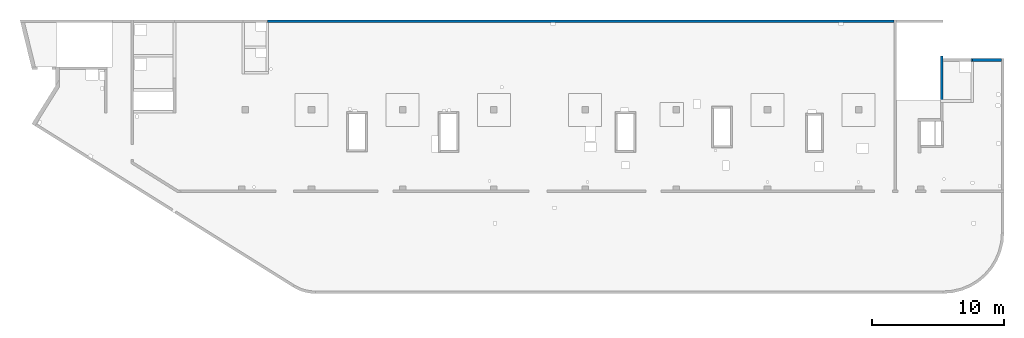
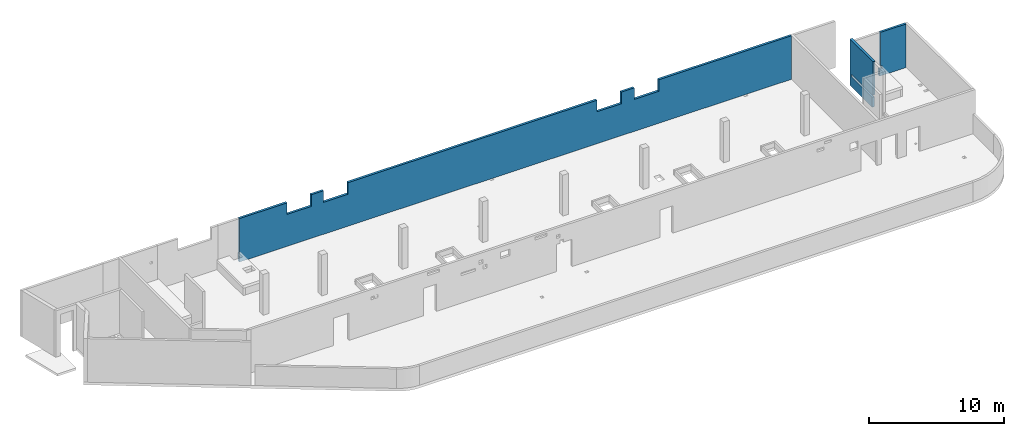
# One storey, part 6 of 6: 3 walls, 4 openings.
"""IFC4 building model written with IfcOpenShell, lengths in millimetres."""

from ifc_helpers import new_model, entity, si_unit, converted_unit, derived_unit, direction, frame, origin, place, context, subcontext, project, spatial, indexed_curve, outline, extrude, polygons, material, type_object, element, save


model = new_model("IFC4")

# Units and contexts
model_context = context("Model", 3, precision=0.01, world=origin(), true_north=direction((6.12303176911189e-17, 1.0)))
plan_context = context("Plan", 3, precision=0.01, world=origin(), true_north=direction((6.12303176911189e-17, 1.0)))
body_context = subcontext(model_context, "Body", "Model", "MODEL_VIEW")
ifc_project = project(units=[si_unit("LENGTHUNIT", "METRE", prefix="MILLI"), si_unit("AREAUNIT", "SQUARE_METRE"), si_unit("VOLUMEUNIT", "CUBIC_METRE"), converted_unit("PLANEANGLEUNIT", "DEGREE", entity("IfcRatioMeasure", 0.0174532925199433), si_unit("PLANEANGLEUNIT", "RADIAN"), dimensions=[0, 0, 0, 0, 0, 0, 0]), si_unit("MASSUNIT", "GRAM", prefix="KILO"), derived_unit("MASSDENSITYUNIT", [(si_unit("MASSUNIT", "GRAM", prefix="KILO"), 1), (si_unit("LENGTHUNIT", "METRE"), -3)]), derived_unit("MOMENTOFINERTIAUNIT", [(si_unit("LENGTHUNIT", "METRE"), 4)]), si_unit("TIMEUNIT", "SECOND"), si_unit("FREQUENCYUNIT", "HERTZ"), si_unit("THERMODYNAMICTEMPERATUREUNIT", "DEGREE_CELSIUS"), derived_unit("THERMALTRANSMITTANCEUNIT", [(si_unit("MASSUNIT", "GRAM", prefix="KILO"), 1), (si_unit("THERMODYNAMICTEMPERATUREUNIT", "KELVIN"), -1), (si_unit("TIMEUNIT", "SECOND"), -3)]), derived_unit("VOLUMETRICFLOWRATEUNIT", [(si_unit("LENGTHUNIT", "METRE"), 3), (si_unit("TIMEUNIT", "SECOND"), -1)]), derived_unit("MASSFLOWRATEUNIT", [(si_unit("MASSUNIT", "GRAM", prefix="KILO"), 1), (si_unit("TIMEUNIT", "SECOND"), -1)]), derived_unit("ROTATIONALFREQUENCYUNIT", [(si_unit("TIMEUNIT", "SECOND"), -1)]), si_unit("ELECTRICCURRENTUNIT", "AMPERE"), si_unit("ELECTRICVOLTAGEUNIT", "VOLT"), si_unit("POWERUNIT", "WATT"), si_unit("FORCEUNIT", "NEWTON", prefix="KILO"), si_unit("ILLUMINANCEUNIT", "LUX"), si_unit("LUMINOUSFLUXUNIT", "LUMEN"), si_unit("LUMINOUSINTENSITYUNIT", "CANDELA"), derived_unit("USERDEFINED", [(si_unit("MASSUNIT", "GRAM", prefix="KILO"), -1), (si_unit("LENGTHUNIT", "METRE"), -2), (si_unit("TIMEUNIT", "SECOND"), 3), (si_unit("LUMINOUSFLUXUNIT", "LUMEN"), 1)]), derived_unit("LINEARVELOCITYUNIT", [(si_unit("LENGTHUNIT", "METRE"), 1), (si_unit("TIMEUNIT", "SECOND"), -1)]), si_unit("PRESSUREUNIT", "PASCAL"), derived_unit("USERDEFINED", [(si_unit("LENGTHUNIT", "METRE"), -2), (si_unit("MASSUNIT", "GRAM", prefix="KILO"), 1), (si_unit("TIMEUNIT", "SECOND"), -2)]), derived_unit("LINEARFORCEUNIT", [(si_unit("MASSUNIT", "GRAM", prefix="KILO"), 1), (si_unit("LENGTHUNIT", "METRE"), 1), (si_unit("TIMEUNIT", "SECOND"), -2), (si_unit("LENGTHUNIT", "METRE"), -1)]), derived_unit("PLANARFORCEUNIT", [(si_unit("MASSUNIT", "GRAM", prefix="KILO"), 1), (si_unit("LENGTHUNIT", "METRE"), 1), (si_unit("TIMEUNIT", "SECOND"), -2), (si_unit("LENGTHUNIT", "METRE"), -2)])], contexts=[model_context, plan_context])

# Site, building, storey
site_placement = place(None, origin())
site = spatial("IfcSite", under=ifc_project, at=site_placement, CompositionType="ELEMENT")
building_placement = place(site_placement, origin())
building = spatial("IfcBuilding", under=site, at=building_placement, CompositionType="ELEMENT")
storey_placement = place(building_placement, frame((0.0, 0.0, 28200.0)))
storey = spatial("IfcBuildingStorey", under=building, at=storey_placement, CompositionType="ELEMENT", Elevation=28200.0)

# Wall
ifc_material = material()
wall_type = type_object("IfcWallType", PredefinedType="STANDARD")
wall_1_placement = place(storey_placement, frame((73369.9994506836, 17469.9992263554, -150.0), z_axis=(0.0, 0.0, 1.0), x_axis=(-1.0, 0.0, 0.0)))
element("IfcWall", 1, at=wall_1_placement, inside=storey, type_object=wall_type, material=ifc_material, PredefinedType="NOTDEFINED", context=body_context, shape_type="Tessellation", body=[
    polygons([(-8.42037747823843e-12, -100.000000000001, 0.0), (2300.00000000001, -100.000000000003, 0.0), (2300.00000000001, -100.000000000003, 650.000000000004), (2100.00000000003, -99.9999999999989, 650.000000000004), (2100.00000000003, -99.9999999999989, 899.999999999999), (2200.00000000001, -100.000000000003, 899.999999999999), (2200.00000000001, -100.000000000003, 3950.0), (-8.42037747823843e-12, -100.000000000001, 3950.0), (2300.00000000001, 99.9999999999968, 0.0), (2100.00000000001, 99.9999999999968, 0.0), (-9.11341244098939e-12, 99.9999999999989, 0.0), (-9.11341244098939e-12, 99.9999999999989, 3950.0), (2200.00000000001, 99.9999999999968, 3950.0), (2200.00000000001, 99.9999999999968, 899.999999999999), (2100.00000000002, 99.9999999999968, 899.999999999999), (2100.00000000002, 99.9999999999968, 650.000000000004), (2300.00000000001, 99.9999999999968, 650.000000000004)], [[[1, 2, 3, 4, 5, 6, 7, 8]], [[9, 10, 11, 12, 13, 14, 15, 16, 17]], [[2, 1, 11, 10, 9]], [[8, 7, 13, 12]], [[1, 8, 12, 11]], [[5, 15, 14, 6]], [[4, 16, 15, 5]], [[13, 7, 6, 14]], [[3, 17, 16, 4]], [[2, 9, 17, 3]]], closed=True),
])

# Wall, openings
wall_2_placement = place(storey_placement, frame((65230.0002685547, 20399.9998657227, -150.0), z_axis=(0.0, 0.0, 1.0), x_axis=(-1.0, 0.0, 0.0)))
wall_2 = element("IfcWall", 2, at=wall_2_placement, inside=storey, type_object=wall_type, material=ifc_material, PredefinedType="NOTDEFINED", context=body_context, shape_type="Tessellation", body=[
    polygons([(-2.29534734415479e-12, -100.000000000003, 0.0), (47405.0, -100.000000000003, 0.0), (47405.0, -100.000000000003, 3950.0), (43325.0000000001, -100.000000000008, 3950.0), (43325.0000000001, -100.000000000328, 2900.00000000001), (41225.0000000001, -100.000000000324, 2900.00000000001), (41225.0000000001, -100.000000000003, 3950.0), (40175.0000000001, -100.000000000008, 3950.0), (40175.0000000001, -100.000000000324, 2900.00000000001), (38075.0000000001, -100.000000000324, 2900.00000000001), (38075.0000000001, -100.000000000003, 3950.0), (16710.0000000001, -100.000000000008, 3950.0), (16710.0000000001, -100.000000000328, 2899.99999999994), (14610.0000000001, -100.000000000324, 2899.99999999994), (14610.0000000001, -100.000000000003, 3950.0), (13510.0000000001, -100.000000000003, 3950.0), (13510.0000000001, -100.000000000324, 2899.99999999993), (11410.0000000001, -100.000000000328, 2899.99999999993), (11410.0000000001, -100.000000000008, 3950.0), (-2.29534734415479e-12, -100.000000000003, 3950.0), (47405.0, 99.9999999999989, 0.0), (47305.0, 99.9999999999946, 0.0), (25930.0, 99.9999999999946, 0.0), (25630.0, 99.9999999999989, 0.0), (4160.00000000003, 99.9999999999989, 0.0), (3860.00000000001, 99.9999999999989, 0.0), (-2.94908538678751e-12, 99.9999999999989, 0.0), (-2.94908538678751e-12, 99.9999999999989, 3950.0), (11410.0000000001, 99.9999999999946, 3950.0), (11410.0000000001, 99.9999999999946, 2899.99999999993), (13510.0000000001, 99.9999999999989, 2899.99999999993), (13510.0000000001, 99.9999999999989, 3950.0), (14610.0000000001, 99.9999999999989, 3950.0), (14610.0000000001, 99.9999999999989, 2899.99999999994), (16710.0000000001, 99.9999999999946, 2899.99999999994), (16710.0000000001, 99.9999999999946, 3950.0), (25630.0, 99.9999999999989, 3950.0), (25930.0, 99.9999999999946, 3950.0), (38075.0000000001, 99.9999999999989, 3950.0), (38075.0000000001, 99.9999999999989, 2900.00000000001), (40175.0000000001, 99.9999999999989, 2900.00000000001), (40175.0000000001, 99.9999999999989, 3950.0), (41225.0000000001, 99.9999999999989, 3950.0), (41225.0000000001, 99.9999999999989, 2900.00000000001), (43325.0000000001, 99.9999999999946, 2900.00000000001), (43325.0000000001, 99.9999999999946, 3950.0), (47405.0, 99.9999999999989, 3950.0)], [[[1, 2, 3, 4, 5, 6, 7, 8, 9, 10, 11, 12, 13, 14, 15, 16, 17, 18, 19, 20]], [[21, 22, 23, 24, 25, 26, 27, 28, 29, 30, 31, 32, 33, 34, 35, 36, 37, 38, 39, 40, 41, 42, 43, 44, 45, 46, 47]], [[2, 1, 27, 26, 25, 24, 23, 22, 21]], [[3, 47, 46, 4]], [[1, 20, 28, 27]], [[2, 21, 47, 3]], [[41, 9, 8, 42]], [[9, 41, 40, 10]], [[10, 40, 39, 11]], [[45, 5, 4, 46]], [[5, 45, 44, 6]], [[6, 44, 43, 7]], [[35, 13, 12, 36]], [[13, 35, 34, 14]], [[14, 34, 33, 15]], [[31, 17, 16, 32]], [[17, 31, 30, 18]], [[18, 30, 29, 19]], [[11, 39, 38, 37, 36, 12]], [[15, 33, 32, 16]], [[42, 8, 7, 43]], [[28, 20, 19, 29]]], closed=True),
])
opening_1_placement = place(wall_2_placement, frame((65230.0002685547, 20399.9998657227, 150.0), z_axis=(0.0, 0.0, 1.0), x_axis=(-1.0, 0.0, 0.0)))
element("IfcOpeningElement", 3, at=opening_1_placement, cuts=wall_2, PredefinedType="OPENING", context=body_context, shape_type="SweptSolid", body=[
    extrude(outline(indexed_curve([(-1050.0, -524.999999999993), (1050.0, -524.999999999993), (1050.0, 524.999999999993), (-1050.0, 524.999999999993), (-1050.0, -524.999999999993)], self_intersect=False)), frame((26105.0002685547, 20499.9998657238, 3275.0), z_axis=(0.0, -1.0, 0.0), x_axis=(-1.0, 0.0, 0.0)), (0.0, 0.0, 1.0), 200.000000000959),
])
opening_2_placement = place(wall_2_placement, frame((65230.0002685547, 20399.9998657227, 150.0), z_axis=(0.0, 0.0, 1.0), x_axis=(-1.0, 0.0, 0.0)))
element("IfcOpeningElement", 4, at=opening_2_placement, cuts=wall_2, PredefinedType="OPENING", context=body_context, shape_type="SweptSolid", body=[
    extrude(outline(indexed_curve([(-1050.0, -524.999999999993), (1050.0, -524.999999999993), (1050.0, 524.999999999993), (-1050.0, 524.999999999993), (-1050.0, -524.999999999993)], self_intersect=False)), frame((22955.0002685547, 20499.9998657238, 3275.0), z_axis=(0.0, -1.0, 0.0), x_axis=(-1.0, 0.0, 0.0)), (0.0, 0.0, 1.0), 200.000000000959),
])
opening_3_placement = place(wall_2_placement, frame((65230.0002685547, 20399.9998657227, 150.0), z_axis=(0.0, 0.0, 1.0), x_axis=(-1.0, 0.0, 0.0)))
element("IfcOpeningElement", 5, at=opening_3_placement, cuts=wall_2, PredefinedType="OPENING", context=body_context, shape_type="SweptSolid", body=[
    extrude(outline(indexed_curve([(-1050.0, -524.999999999993), (1050.0, -524.999999999993), (1050.0, 524.999999999993), (-1050.0, 524.999999999993), (-1050.0, -524.999999999993)], self_intersect=False)), frame((49570.0002685547, 20499.9998657237, 3275.0), z_axis=(0.0, -1.0, 0.0), x_axis=(-1.0, 0.0, 0.0)), (0.0, 0.0, 1.0), 200.000000000959),
])
opening_4_placement = place(wall_2_placement, frame((65230.0002685547, 20399.9998657227, 150.0), z_axis=(0.0, 0.0, 1.0), x_axis=(-1.0, 0.0, 0.0)))
element("IfcOpeningElement", 6, at=opening_4_placement, cuts=wall_2, PredefinedType="OPENING", context=body_context, shape_type="SweptSolid", body=[
    extrude(outline(indexed_curve([(-1050.0, -524.999999999993), (1050.0, -524.999999999993), (1050.0, 524.999999999993), (-1050.0, 524.999999999993), (-1050.0, -524.999999999993)], self_intersect=False)), frame((52770.0002685547, 20499.9998657237, 3275.0), z_axis=(0.0, -1.0, 0.0), x_axis=(-1.0, 0.0, 0.0)), (0.0, 0.0, 1.0), 200.000000000959),
])

# Wall
wall_3_placement = place(storey_placement, frame((68870.0002685547, 17779.9992263555, -400.0), z_axis=(0.0, 0.0, 1.0), x_axis=(0.0, -1.0, 0.0)))
element("IfcWall", 7, at=wall_3_placement, inside=storey, type_object=wall_type, material=ifc_material, PredefinedType="NOTDEFINED", context=body_context, shape_type="Tessellation", body=[
    polygons([(2.16573425859679e-12, -99.9999999999978, 0.0), (3310.0, -99.9999999999978, 0.0), (3310.0, -99.9999999999978, 249.999999999999), (3310.0, -99.9999999999978, 900.000000000003), (210.000000000024, -100.000000000006, 900.000000000003), (210.000000000024, -100.000000000006, 1150.0), (3410.0, -99.9999999999976, 1150.0), (3410.0, -99.9999999999976, 4200.0), (3349.99999999998, -99.9999999999977, 4200.0), (210.000000000004, -99.9999999999973, 4200.0), (2.16573425859679e-12, -99.9999999999978, 4200.0), (3310.0, 100.0, 0.0), (410.0, 100.000000000001, 0.0), (210.0, 100.000000000001, 0.0), (2.16573425859679e-12, 100.000000000009, 0.0), (2.16573425859679e-12, 100.000000000009, 4200.0), (210.0, 100.000000000001, 4200.0), (410.0, 100.000000000001, 4200.0), (3410.0, 100.0, 4200.0), (3410.0, 100.0, 1150.0), (410.0, 100.000000000001, 1150.0), (210.000000000024, 100.000000000009, 1150.0), (210.000000000024, 100.000000000009, 900.000000000003), (410.0, 100.000000000001, 899.999999999999), (3310.0, 100.0, 900.000000000003)], [[[1, 2, 3, 4, 5, 6, 7, 8, 9, 10, 11]], [[12, 13, 14, 15, 16, 17, 18, 19, 20, 21, 22, 23, 24, 25]], [[2, 1, 15, 14, 13, 12]], [[11, 10, 9, 8, 19, 18, 17, 16]], [[1, 11, 16, 15]], [[23, 5, 4, 25, 24]], [[6, 22, 21, 20, 7]], [[5, 23, 22, 6]], [[19, 8, 7, 20]], [[2, 12, 25, 4, 3]]], closed=True),
])

save(model, "model.ifc")
